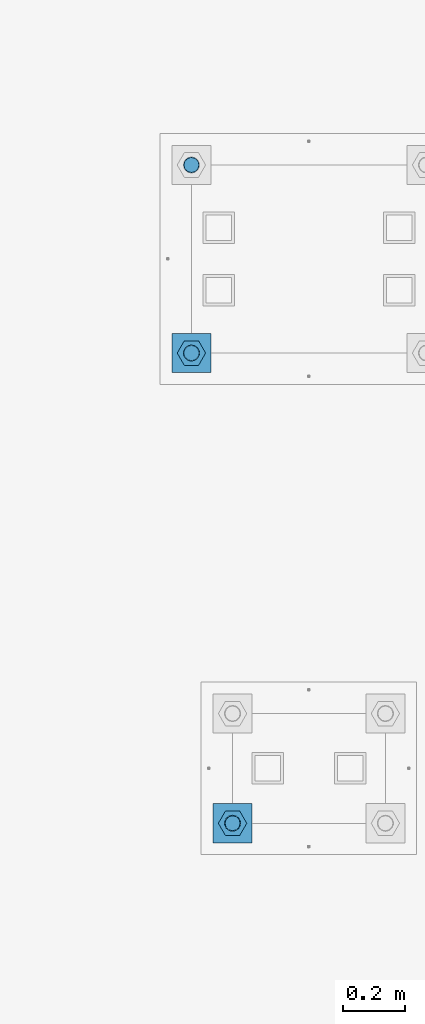
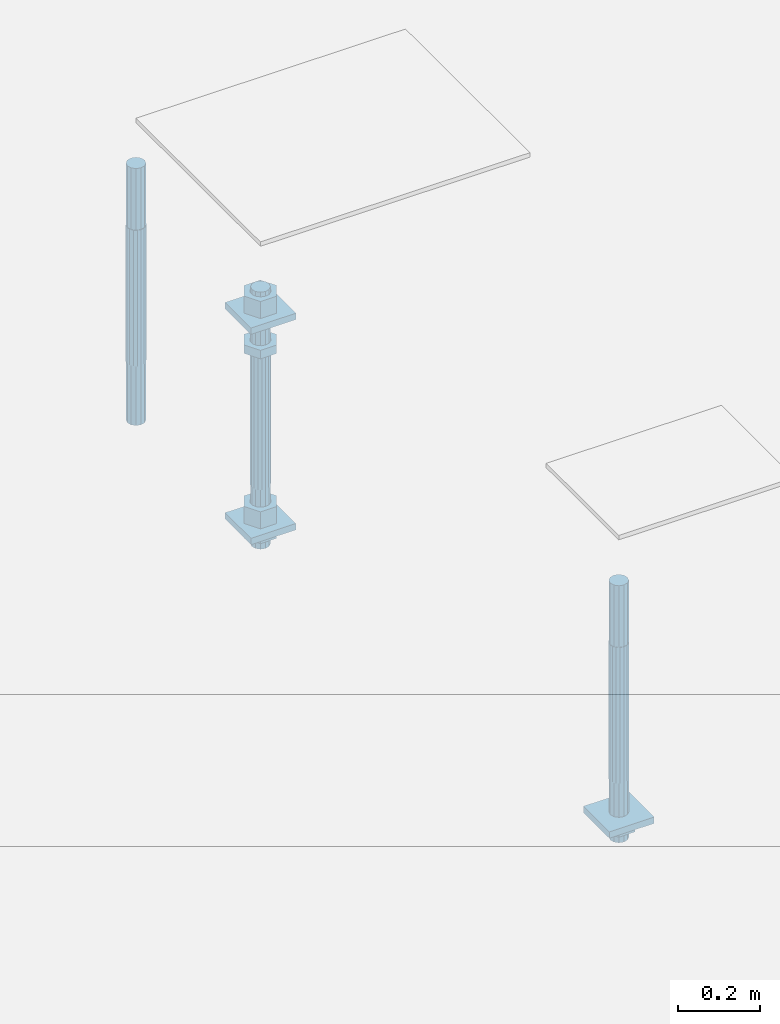
# One storey, part 2558 of 3843: 11 beams, 2 elements without a shape of their own.
"""IFC2X3 building model written with IfcOpenShell, lengths in millimetres."""

import ifcopenshell
import ifcopenshell.guid

model = None  # the IFC model being written
_history = None  # IfcOwnerHistory: only IFC2X3 demands one
_inside = {}  # id of a spatial element -> (the spatial element, [elements in it])
_under = {}  # id of a project, library or spatial element -> (it, [spatial elements below it])
_declared = {}  # id of a project -> (the project, [libraries it declares])
_typed = {}  # id of a type object -> (the type object, [elements of that type])
_made_of = {}  # id of a material, layer set ... -> (it, [elements and type objects made of it])


def new_model(schema):
    """Start an empty IFC model of exactly this schema.

    Asked for "IFC4X3", IfcOpenShell would pick the latest addendum, in which some entities
    have other attributes; the version numbers below select the first issue.
    IFC2X3 requires an IfcOwnerHistory on every rooted entity: one is made here for all.
    """
    global model, _history
    if schema == "IFC4X3":
        model = ifcopenshell.file(schema_version=(4, 3, 0, 0))
    else:
        model = ifcopenshell.file(schema=schema)
    _inside.clear()
    _under.clear()
    _declared.clear()
    _typed.clear()
    _made_of.clear()
    _history = None
    if model.schema == "IFC2X3":
        org = make("IfcOrganization", Name="unknown")
        user = make(
            "IfcPersonAndOrganization",
            ThePerson=make("IfcPerson", FamilyName="unknown"),
            TheOrganization=org,
        )
        app = make(
            "IfcApplication",
            ApplicationDeveloper=org,
            Version="unknown",
            ApplicationFullName="unknown",
            ApplicationIdentifier="unknown",
        )
        _history = make(
            "IfcOwnerHistory",
            OwningUser=user,
            OwningApplication=app,
            ChangeAction="ADDED",
            CreationDate=0,
        )
    return model


def make(cls, **values):
    """One entity of the class cls with the attributes given. An attribute that is None is left unset."""
    return model.create_entity(
        cls, **{name: value for name, value in values.items() if value is not None}
    )


def rooted(cls, **values):
    """An entity with a GlobalId (a new one), such as an element, a storey or a relation."""
    return make(cls, GlobalId=ifcopenshell.guid.new(), OwnerHistory=_history, **values)


def si_unit(unit_type, name, prefix=None):
    """IfcSIUnit, for example si_unit("LENGTHUNIT", "METRE", prefix="MILLI")."""
    return make("IfcSIUnit", UnitType=unit_type, Prefix=prefix, Name=name)


def assignment(units):
    """IfcUnitAssignment: the units of a project."""
    return None if units is None else make("IfcUnitAssignment", Units=units)


def point(xyz):
    """IfcCartesianPoint."""
    return None if xyz is None else make("IfcCartesianPoint", Coordinates=xyz)


def direction(xyz):
    """IfcDirection."""
    return None if xyz is None else make("IfcDirection", DirectionRatios=xyz)


def frame(location, z_axis=None, x_axis=None):
    """IfcAxis2Placement3D, a coordinate frame: its origin and axes. An axis left out is left unset."""
    return make(
        "IfcAxis2Placement3D",
        Location=point(location),
        Axis=direction(z_axis),
        RefDirection=direction(x_axis),
    )


def origin_with_axes():
    """The frame at (0, 0, 0) with the z axis (0, 0, 1) and the x axis (1, 0, 0) written out."""
    return frame((0.0, 0.0, 0.0), z_axis=(0.0, 0.0, 1.0), x_axis=(1.0, 0.0, 0.0))


def place(relative_to, where):
    """IfcLocalPlacement: puts the frame where relative to a parent placement (None: the world)."""
    return make(
        "IfcLocalPlacement", PlacementRelTo=relative_to, RelativePlacement=where
    )


def context(
    kind, dimensions, precision=None, world=None, true_north=None, identifier=None
):
    """IfcGeometricRepresentationContext, for example the 3D "Model" context."""
    return make(
        "IfcGeometricRepresentationContext",
        ContextIdentifier=identifier,
        ContextType=kind,
        CoordinateSpaceDimension=dimensions,
        Precision=precision,
        WorldCoordinateSystem=world,
        TrueNorth=true_north,
    )


def subcontext(parent, identifier, kind, view, scale=None):
    """IfcGeometricRepresentationSubContext, for example "Body" below "Model"."""
    return make(
        "IfcGeometricRepresentationSubContext",
        ContextIdentifier=identifier,
        ContextType=kind,
        ParentContext=parent,
        TargetScale=scale,
        TargetView=view,
    )


def project(units=None, contexts=None):
    """IfcProject with its units and contexts."""
    return rooted(
        "IfcProject",
        Name="project",
        RepresentationContexts=contexts,
        UnitsInContext=assignment(units),
    )


def spatial(cls, under=None, at=None, **own):
    """A site, building, storey or space (cls), placed at a placement, below another one or the project."""
    s = rooted(cls, ObjectPlacement=at, **own)
    if under is not None:
        _under.setdefault(under.id(), (under, []))[1].append(s)
    return s


def faces_of(points, faces, orient=None, outer=None):
    """IfcFace entities. A face is a list of loops; a loop is a list of indices into points, from 0.

    orient and outer hold one flag for each loop. By default every Orientation is true, the
    first loop of a face is its IfcFaceOuterBound and the others are IfcFaceBound.
    """
    made = []
    for i, loops in enumerate(faces):
        bounds = []
        for j, loop in enumerate(loops):
            is_outer = j == 0 if outer is None else outer[i][j]
            bounds.append(
                make(
                    "IfcFaceOuterBound" if is_outer else "IfcFaceBound",
                    Bound=make("IfcPolyLoop", Polygon=[points[k] for k in loop]),
                    Orientation=True if orient is None else orient[i][j],
                )
            )
        made.append(make("IfcFace", Bounds=bounds))
    return made


def faceted_brep(points, faces, orient=None, outer=None, voids=None):
    """IfcFacetedBrep: a solid bounded by flat faces; with voids (closed shells), ...WithVoids."""
    shared = [point(p) for p in points]
    hull = make("IfcClosedShell", CfsFaces=faces_of(shared, faces, orient, outer))
    if voids is None:
        return make("IfcFacetedBrep", Outer=hull)
    return make(
        "IfcFacetedBrepWithVoids",
        Outer=hull,
        Voids=[
            make(cls, CfsFaces=faces_of(shared, fs, o, b)) for cls, fs, o, b in voids
        ],
    )


def shape(context_of_items, identifier, shape_type, items):
    """IfcShapeRepresentation: the items that make up one representation, for example the "Body"."""
    return make(
        "IfcShapeRepresentation",
        ContextOfItems=context_of_items,
        RepresentationIdentifier=identifier,
        RepresentationType=shape_type,
        Items=items,
    )


def material(Name=None, Category=None):
    """IfcMaterial."""
    return make("IfcMaterial", Name=Name, Category=Category)


def made_of(thing, what):
    """Note that an element or type object is made of a material, layer set ...; save() writes the relation."""
    if what is not None:
        _made_of.setdefault(what.id(), (what, []))[1].append(thing)
    return thing


def type_object(cls, material=None, **own):
    """A type object (cls), such as IfcWallType, which elements share."""
    return made_of(rooted(cls, **own), material)


def element(
    cls,
    number,
    at=None,
    inside=None,
    cuts=None,
    type_object=None,
    material=None,
    context=None,
    identifier="Body",
    shape_type=None,
    held_by="IfcProductDefinitionShape",
    body=None,
    shapes=None,
    **own,
):
    """One element of the class cls, such as IfcWall. Its Tag is "e" and its number.

    at: its placement. inside: the storey or other place that contains it. cuts: it is an
    opening in that element (IfcRelVoidsElement). A single representation is given by context,
    identifier, shape_type and body (its items); several are given by shapes. held_by: the class
    of the entity that holds the representations. save() writes the other relations.
    """
    e = rooted(cls, Tag="e%d" % number, ObjectPlacement=at, **own)
    if body is not None:
        shapes = [shape(context, identifier, shape_type, body)]
    if shapes is not None:
        e.Representation = make(held_by, Representations=shapes)
    if inside is not None:
        _inside.setdefault(inside.id(), (inside, []))[1].append(e)
    if cuts is not None:
        rooted(
            "IfcRelVoidsElement", RelatingBuildingElement=cuts, RelatedOpeningElement=e
        )
    if type_object is not None:
        _typed.setdefault(type_object.id(), (type_object, []))[1].append(e)
    return made_of(e, material)


def aggregate(whole, parts):
    """IfcRelAggregates: a whole, such as a stair, and the parts it consists of."""
    return rooted("IfcRelAggregates", RelatingObject=whole, RelatedObjects=parts)


def save(model, path):
    """Write the relations noted so far, then the file.

    IfcRelAggregates (storeys below a building ...), IfcRelContainedInSpatialStructure (elements
    in a storey), IfcRelDefinesByType, IfcRelAssociatesMaterial and IfcRelDeclares: one each for
    every whole, place, type object, material and project.
    """
    for whole, parts in _under.values():
        aggregate(whole, parts)
    for where, things in _inside.values():
        rooted(
            "IfcRelContainedInSpatialStructure",
            RelatedElements=things,
            RelatingStructure=where,
        )
    for kind, things in _typed.values():
        rooted("IfcRelDefinesByType", RelatedObjects=things, RelatingType=kind)
    for what, things in _made_of.values():
        rooted("IfcRelAssociatesMaterial", RelatedObjects=things, RelatingMaterial=what)
    for by, libraries in _declared.values():
        rooted("IfcRelDeclares", RelatingContext=by, RelatedDefinitions=libraries)
    model.write(path)


model = new_model("IFC2X3")

# Units and contexts
model_context = context("Model", 3, precision=1e-05, world=origin_with_axes())
body_context = subcontext(model_context, "Body", "Model", "MODEL_VIEW")
ifc_project = project(units=[si_unit("LENGTHUNIT", "METRE", prefix="MILLI"), si_unit("AREAUNIT", "SQUARE_METRE"), si_unit("VOLUMEUNIT", "CUBIC_METRE"), si_unit("MASSUNIT", "GRAM", prefix="KILO"), si_unit("TIMEUNIT", "SECOND"), si_unit("PLANEANGLEUNIT", "RADIAN"), si_unit("SOLIDANGLEUNIT", "STERADIAN"), si_unit("THERMODYNAMICTEMPERATUREUNIT", "DEGREE_CELSIUS"), si_unit("LUMINOUSINTENSITYUNIT", "LUMEN")], contexts=[model_context])

# Site, building, storey
site_placement = place(None, origin_with_axes())
site = spatial("IfcSite", under=ifc_project, at=site_placement, CompositionType="ELEMENT")
building_placement = place(site_placement, origin_with_axes())
building = spatial("IfcBuilding", under=site, at=building_placement, Name="Undefined", CompositionType="ELEMENT")
storey_placement = place(building_placement, origin_with_axes())
storey = spatial("IfcBuildingStorey", under=building, at=storey_placement, Name="Undefined", CompositionType="ELEMENT", Elevation=0.0)

# Assembly, beam
assembly_1_placement = place(storey_placement, origin_with_axes())
assembly_1 = element("IfcElementAssembly", 1, at=assembly_1_placement, inside=storey, Name="TEMPLATE", AssemblyPlace="NOTDEFINED", PredefinedType="RIGID_FRAME")
ifc_material_1 = material(Name="STEEL/A572-50")
beam_type_1 = type_object("IfcBeamType", PredefinedType="NOTDEFINED")
beam_1_placement = place(assembly_1_placement, frame((104908.35, -114.300001525879, 29244.925), z_axis=(-1.0, 0.0, 0.0), x_axis=(0.0, -1.0, 0.0)))
beam_1 = element("IfcBeam", 2, at=beam_1_placement, type_object=beam_type_1, material=ifc_material_1, Name="WASHER_PLATE", context=body_context, shape_type="Brep", body=[
    faceted_brep([(0.0, 9.52500000000146, -63.5), (0.0, 9.52500000000146, 63.5), (127.0, 9.52500000000146, 63.5), (127.0, 9.52500000000146, -63.5), (0.0, -9.52500000000146, 63.5), (127.0, -9.52500000000146, 63.5), (0.0, -9.52500000000146, -63.5), (127.0, -9.52500000000146, -63.5)], [[[0, 1, 2, 3]], [[1, 4, 5, 2]], [[4, 6, 7, 5]], [[6, 0, 3, 7]], [[5, 7, 3, 2]], [[6, 4, 1, 0]]]),
])

# Assembly, beams
assembly_2_placement = place(storey_placement, origin_with_axes())
assembly_2 = element("IfcElementAssembly", 3, at=assembly_2_placement, inside=storey, Name="TEMPLATE", AssemblyPlace="NOTDEFINED", PredefinedType="RIGID_FRAME")
beam_2_placement = place(assembly_2_placement, frame((104775.0, 1282.70000152587, 29873.575), z_axis=(1.0, 0.0, 0.0), x_axis=(0.0, 1.0, 0.0)))
beam_2 = element("IfcBeam", 4, at=beam_2_placement, type_object=beam_type_1, material=ifc_material_1, Name="WASHER_PLATE", context=body_context, shape_type="Brep", body=[
    faceted_brep([(0.0, 9.52500000000146, -63.5), (0.0, 9.52500000000146, 63.5), (127.0, 9.52500000000146, 63.5), (127.0, 9.52500000000146, -63.5), (0.0, -9.52500000000146, 63.5), (127.0, -9.52500000000146, 63.5), (0.0, -9.52500000000146, -63.5), (127.0, -9.52500000000146, -63.5)], [[[0, 1, 2, 3]], [[1, 4, 5, 2]], [[4, 6, 7, 5]], [[6, 0, 3, 7]], [[5, 7, 3, 2]], [[6, 4, 1, 0]]]),
])
beam_3_placement = place(assembly_2_placement, frame((104775.0, 1282.70000152587, 29244.925), z_axis=(1.0, 0.0, 0.0), x_axis=(0.0, 1.0, 0.0)))
beam_3 = element("IfcBeam", 5, at=beam_3_placement, type_object=beam_type_1, material=ifc_material_1, Name="WASHER_PLATE", context=body_context, shape_type="Brep", body=[
    faceted_brep([(0.0, 9.52500000000146, -63.5), (0.0, 9.52500000000146, 63.5), (127.0, 9.52500000000146, 63.5), (127.0, 9.52500000000146, -63.5), (0.0, -9.52500000000146, 63.5), (127.0, -9.52500000000146, 63.5), (0.0, -9.52500000000146, -63.5), (127.0, -9.52500000000146, -63.5)], [[[0, 1, 2, 3]], [[1, 4, 5, 2]], [[4, 6, 7, 5]], [[6, 0, 3, 7]], [[5, 7, 3, 2]], [[6, 4, 1, 0]]]),
])

# Beam
ifc_material_2 = material(Name="STEEL/A36")
beam_type_2 = type_object("IfcBeamType", Name="2_HALF_NUT", PredefinedType="NOTDEFINED")
beam_4_placement = place(assembly_1_placement, frame((104908.35, -177.800001525879, 29235.4), z_axis=(0.0, -1.0, 0.0), x_axis=(0.0, 0.0, -1.0)))
beam_4 = element("IfcBeam", 6, at=beam_4_placement, type_object=beam_type_2, material=ifc_material_2, Name="NUT", ObjectType="2_HALF_NUT", context=body_context, shape_type="Brep", body=[
    faceted_brep([(0.0, -46.0369987487793, 0.0), (0.0, -23.0184993743896, -39.869213104248), (25.4000000000015, -23.0184993743896, -39.869213104248), (25.4000000000015, -46.0369987487793, 0.0), (0.0, 23.0184993743896, -39.869213104248), (25.4000000000015, 23.0184993743896, -39.869213104248), (0.0, 46.0369987487793, 0.0), (25.4000000000015, 46.0369987487793, 0.0), (0.0, 23.0184993743896, 39.869213104248), (25.4000000000015, 23.0184993743896, 39.869213104248), (0.0, -23.0184993743896, 39.869213104248), (25.4000000000015, -23.0184993743896, 39.869213104248), (0.0, 0.0, 26.1940002441406), (0.0, 11.3650617044477, 23.5999013092805), (25.4000000000015, 11.3650617044477, 23.5999013092805), (25.4000000000015, 0.0, 26.1940002441406), (0.0, 20.4791109456419, 16.3316083006721), (25.4000000000015, 20.4791109456419, 16.3316083006721), (0.0, 25.5370200498292, 5.82867859874386), (25.4000000000015, 25.5370200498292, 5.82867859874386), (0.0, 25.5370200498292, -5.82867859874386), (25.4000000000015, 25.5370200498292, -5.82867859874386), (0.0, 20.4791109456419, -16.3316083006721), (25.4000000000015, 20.4791109456419, -16.3316083006721), (0.0, 11.3650617044477, -23.5999013092805), (25.4000000000015, 11.3650617044477, -23.5999013092805), (0.0, 0.0, -26.1940002441406), (25.4000000000015, 0.0, -26.1940002441406), (0.0, -11.3650617044477, -23.5999013092805), (25.4000000000015, -11.3650617044477, -23.5999013092805), (0.0, -20.4791109456419, -16.3316083006721), (25.4000000000015, -20.4791109456419, -16.3316083006721), (0.0, -25.5370200498292, -5.82867859874386), (25.4000000000015, -25.5370200498292, -5.82867859874386), (0.0, -25.5370200498292, 5.82867859874386), (25.4000000000015, -25.5370200498292, 5.82867859874386), (0.0, -20.4791109456419, 16.3316083006721), (25.4000000000015, -20.4791109456419, 16.3316083006721), (0.0, -11.3650617044477, 23.5999013092805), (25.4000000000015, -11.3650617044477, 23.5999013092805)], [[[0, 1, 2, 3]], [[1, 4, 5, 2]], [[4, 6, 7, 5]], [[6, 8, 9, 7]], [[8, 10, 11, 9]], [[10, 0, 3, 11]], [[12, 13, 14, 15]], [[13, 16, 17, 14]], [[16, 18, 19, 17]], [[18, 20, 21, 19]], [[20, 22, 23, 21]], [[22, 24, 25, 23]], [[24, 26, 27, 25]], [[26, 28, 29, 27]], [[28, 30, 31, 29]], [[30, 32, 33, 31]], [[32, 34, 35, 33]], [[34, 36, 37, 35]], [[36, 38, 39, 37]], [[38, 12, 15, 39]], [[5, 7, 9, 11, 3, 2], [17, 19, 21, 23, 25, 27, 29, 31, 33, 35, 37, 39, 15, 14]], [[10, 8, 6, 4, 1, 0], [38, 36, 34, 32, 30, 28, 26, 24, 22, 20, 18, 16, 13, 12]]]),
])

beam_5_placement = place(assembly_2_placement, frame((104775.0, 1346.20000152587, 29787.85), z_axis=(0.0, 1.0, 0.0), x_axis=(0.0, 0.0, -1.0)))
beam_5 = element("IfcBeam", 7, at=beam_5_placement, type_object=beam_type_2, material=ifc_material_2, Name="NUT", ObjectType="2_HALF_NUT", context=body_context, shape_type="Brep", body=[
    faceted_brep([(0.0, -46.0369987487793, 0.0), (0.0, -23.0184993743896, -39.869213104248), (25.4000000000015, -23.0184993743896, -39.869213104248), (25.4000000000015, -46.0369987487793, 0.0), (0.0, 23.0184993743896, -39.869213104248), (25.4000000000015, 23.0184993743896, -39.869213104248), (0.0, 46.0369987487793, 0.0), (25.4000000000015, 46.0369987487793, 0.0), (0.0, 23.0184993743896, 39.869213104248), (25.4000000000015, 23.0184993743896, 39.869213104248), (0.0, -23.0184993743896, 39.869213104248), (25.4000000000015, -23.0184993743896, 39.869213104248), (0.0, 0.0, 26.1940002441406), (0.0, 11.3650617044477, 23.5999013092805), (25.4000000000015, 11.3650617044477, 23.5999013092805), (25.4000000000015, 0.0, 26.1940002441406), (0.0, 20.4791109456419, 16.3316083006721), (25.4000000000015, 20.4791109456419, 16.3316083006721), (0.0, 25.5370200498292, 5.82867859874386), (25.4000000000015, 25.5370200498292, 5.82867859874386), (0.0, 25.5370200498292, -5.82867859874386), (25.4000000000015, 25.5370200498292, -5.82867859874386), (0.0, 20.4791109456419, -16.3316083006721), (25.4000000000015, 20.4791109456419, -16.3316083006721), (0.0, 11.3650617044477, -23.5999013092805), (25.4000000000015, 11.3650617044477, -23.5999013092805), (0.0, 0.0, -26.1940002441406), (25.4000000000015, 0.0, -26.1940002441406), (0.0, -11.3650617044477, -23.5999013092805), (25.4000000000015, -11.3650617044477, -23.5999013092805), (0.0, -20.4791109456419, -16.3316083006721), (25.4000000000015, -20.4791109456419, -16.3316083006721), (0.0, -25.5370200498292, -5.82867859874386), (25.4000000000015, -25.5370200498292, -5.82867859874386), (0.0, -25.5370200498292, 5.82867859874386), (25.4000000000015, -25.5370200498292, 5.82867859874386), (0.0, -20.4791109456419, 16.3316083006721), (25.4000000000015, -20.4791109456419, 16.3316083006721), (0.0, -11.3650617044477, 23.5999013092805), (25.4000000000015, -11.3650617044477, 23.5999013092805)], [[[0, 1, 2, 3]], [[1, 4, 5, 2]], [[4, 6, 7, 5]], [[6, 8, 9, 7]], [[8, 10, 11, 9]], [[10, 0, 3, 11]], [[12, 13, 14, 15]], [[13, 16, 17, 14]], [[16, 18, 19, 17]], [[18, 20, 21, 19]], [[20, 22, 23, 21]], [[22, 24, 25, 23]], [[24, 26, 27, 25]], [[26, 28, 29, 27]], [[28, 30, 31, 29]], [[30, 32, 33, 31]], [[32, 34, 35, 33]], [[34, 36, 37, 35]], [[36, 38, 39, 37]], [[38, 12, 15, 39]], [[5, 7, 9, 11, 3, 2], [17, 19, 21, 23, 25, 27, 29, 31, 33, 35, 37, 39, 15, 14]], [[10, 8, 6, 4, 1, 0], [38, 36, 34, 32, 30, 28, 26, 24, 22, 20, 18, 16, 13, 12]]]),
])

beam_6_placement = place(assembly_2_placement, frame((104775.0, 1346.20000152587, 29235.4), z_axis=(0.0, 1.0, 0.0), x_axis=(0.0, 0.0, -1.0)))
beam_6 = element("IfcBeam", 8, at=beam_6_placement, type_object=beam_type_2, material=ifc_material_2, Name="NUT", ObjectType="2_HALF_NUT", context=body_context, shape_type="Brep", body=[
    faceted_brep([(0.0, -46.0369987487793, 0.0), (0.0, -23.0184993743896, -39.869213104248), (25.4000000000015, -23.0184993743896, -39.869213104248), (25.4000000000015, -46.0369987487793, 0.0), (0.0, 23.0184993743896, -39.869213104248), (25.4000000000015, 23.0184993743896, -39.869213104248), (0.0, 46.0369987487793, 0.0), (25.4000000000015, 46.0369987487793, 0.0), (0.0, 23.0184993743896, 39.869213104248), (25.4000000000015, 23.0184993743896, 39.869213104248), (0.0, -23.0184993743896, 39.869213104248), (25.4000000000015, -23.0184993743896, 39.869213104248), (0.0, 0.0, 26.1940002441406), (0.0, 11.3650617044477, 23.5999013092805), (25.4000000000015, 11.3650617044477, 23.5999013092805), (25.4000000000015, 0.0, 26.1940002441406), (0.0, 20.4791109456419, 16.3316083006721), (25.4000000000015, 20.4791109456419, 16.3316083006721), (0.0, 25.5370200498292, 5.82867859874386), (25.4000000000015, 25.5370200498292, 5.82867859874386), (0.0, 25.5370200498292, -5.82867859874386), (25.4000000000015, 25.5370200498292, -5.82867859874386), (0.0, 20.4791109456419, -16.3316083006721), (25.4000000000015, 20.4791109456419, -16.3316083006721), (0.0, 11.3650617044477, -23.5999013092805), (25.4000000000015, 11.3650617044477, -23.5999013092805), (0.0, 0.0, -26.1940002441406), (25.4000000000015, 0.0, -26.1940002441406), (0.0, -11.3650617044477, -23.5999013092805), (25.4000000000015, -11.3650617044477, -23.5999013092805), (0.0, -20.4791109456419, -16.3316083006721), (25.4000000000015, -20.4791109456419, -16.3316083006721), (0.0, -25.5370200498292, -5.82867859874386), (25.4000000000015, -25.5370200498292, -5.82867859874386), (0.0, -25.5370200498292, 5.82867859874386), (25.4000000000015, -25.5370200498292, 5.82867859874386), (0.0, -20.4791109456419, 16.3316083006721), (25.4000000000015, -20.4791109456419, 16.3316083006721), (0.0, -11.3650617044477, 23.5999013092805), (25.4000000000015, -11.3650617044477, 23.5999013092805)], [[[0, 1, 2, 3]], [[1, 4, 5, 2]], [[4, 6, 7, 5]], [[6, 8, 9, 7]], [[8, 10, 11, 9]], [[10, 0, 3, 11]], [[12, 13, 14, 15]], [[13, 16, 17, 14]], [[16, 18, 19, 17]], [[18, 20, 21, 19]], [[20, 22, 23, 21]], [[22, 24, 25, 23]], [[24, 26, 27, 25]], [[26, 28, 29, 27]], [[28, 30, 31, 29]], [[30, 32, 33, 31]], [[32, 34, 35, 33]], [[34, 36, 37, 35]], [[36, 38, 39, 37]], [[38, 12, 15, 39]], [[5, 7, 9, 11, 3, 2], [17, 19, 21, 23, 25, 27, 29, 31, 33, 35, 37, 39, 15, 14]], [[10, 8, 6, 4, 1, 0], [38, 36, 34, 32, 30, 28, 26, 24, 22, 20, 18, 16, 13, 12]]]),
])

beam_type_3 = type_object("IfcBeamType", Name="2_HEAVY_HEX_NUT", PredefinedType="NOTDEFINED")
beam_7_placement = place(assembly_2_placement, frame((104775.0, 1346.20000152587, 29933.9), z_axis=(0.0, 1.0, 0.0), x_axis=(0.0, 0.0, -1.0)))
beam_7 = element("IfcBeam", 9, at=beam_7_placement, type_object=beam_type_3, material=ifc_material_2, Name="NUT", ObjectType="2_HEAVY_HEX_NUT", context=body_context, shape_type="Brep", body=[
    faceted_brep([(0.0, -46.0369987487793, 0.0), (0.0, -23.0184993743896, -39.869213104248), (50.7999999999993, -23.0184993743896, -39.869213104248), (50.7999999999993, -46.0369987487793, 0.0), (0.0, 23.0184993743896, -39.869213104248), (50.7999999999993, 23.0184993743896, -39.869213104248), (0.0, 46.0369987487793, 0.0), (50.7999999999993, 46.0369987487793, 0.0), (0.0, 23.0184993743896, 39.869213104248), (50.7999999999993, 23.0184993743896, 39.869213104248), (0.0, -23.0184993743896, 39.869213104248), (50.7999999999993, -23.0184993743896, 39.869213104248), (0.0, 0.0, 26.1940002441406), (0.0, 11.3650617044477, 23.5999013092805), (50.7999999999993, 11.3650617044477, 23.5999013092805), (50.7999999999993, 0.0, 26.1940002441406), (0.0, 20.4791109456419, 16.3316083006721), (50.7999999999993, 20.4791109456419, 16.3316083006721), (0.0, 25.5370200498292, 5.82867859874386), (50.7999999999993, 25.5370200498292, 5.82867859874386), (0.0, 25.5370200498292, -5.82867859874386), (50.7999999999993, 25.5370200498292, -5.82867859874386), (0.0, 20.4791109456419, -16.3316083006721), (50.7999999999993, 20.4791109456419, -16.3316083006721), (0.0, 11.3650617044477, -23.5999013092805), (50.7999999999993, 11.3650617044477, -23.5999013092805), (0.0, 0.0, -26.1940002441406), (50.7999999999993, 0.0, -26.1940002441406), (0.0, -11.3650617044477, -23.5999013092805), (50.7999999999993, -11.3650617044477, -23.5999013092805), (0.0, -20.4791109456419, -16.3316083006721), (50.7999999999993, -20.4791109456419, -16.3316083006721), (0.0, -25.5370200498292, -5.82867859874386), (50.7999999999993, -25.5370200498292, -5.82867859874386), (0.0, -25.5370200498292, 5.82867859874386), (50.7999999999993, -25.5370200498292, 5.82867859874386), (0.0, -20.4791109456419, 16.3316083006721), (50.7999999999993, -20.4791109456419, 16.3316083006721), (0.0, -11.3650617044477, 23.5999013092805), (50.7999999999993, -11.3650617044477, 23.5999013092805)], [[[0, 1, 2, 3]], [[1, 4, 5, 2]], [[4, 6, 7, 5]], [[6, 8, 9, 7]], [[8, 10, 11, 9]], [[10, 0, 3, 11]], [[12, 13, 14, 15]], [[13, 16, 17, 14]], [[16, 18, 19, 17]], [[18, 20, 21, 19]], [[20, 22, 23, 21]], [[22, 24, 25, 23]], [[24, 26, 27, 25]], [[26, 28, 29, 27]], [[28, 30, 31, 29]], [[30, 32, 33, 31]], [[32, 34, 35, 33]], [[34, 36, 37, 35]], [[36, 38, 39, 37]], [[38, 12, 15, 39]], [[5, 7, 9, 11, 3, 2], [17, 19, 21, 23, 25, 27, 29, 31, 33, 35, 37, 39, 15, 14]], [[10, 8, 6, 4, 1, 0], [38, 36, 34, 32, 30, 28, 26, 24, 22, 20, 18, 16, 13, 12]]]),
])

beam_8_placement = place(assembly_2_placement, frame((104775.0, 1346.20000152587, 29305.25), z_axis=(0.0, 1.0, 0.0), x_axis=(0.0, 0.0, -1.0)))
beam_8 = element("IfcBeam", 10, at=beam_8_placement, type_object=beam_type_3, material=ifc_material_2, Name="NUT", ObjectType="2_HEAVY_HEX_NUT", context=body_context, shape_type="Brep", body=[
    faceted_brep([(0.0, -46.0369987487793, 0.0), (0.0, -23.0184993743896, -39.869213104248), (50.7999999999993, -23.0184993743896, -39.869213104248), (50.7999999999993, -46.0369987487793, 0.0), (0.0, 23.0184993743896, -39.869213104248), (50.7999999999993, 23.0184993743896, -39.869213104248), (0.0, 46.0369987487793, 0.0), (50.7999999999993, 46.0369987487793, 0.0), (0.0, 23.0184993743896, 39.869213104248), (50.7999999999993, 23.0184993743896, 39.869213104248), (0.0, -23.0184993743896, 39.869213104248), (50.7999999999993, -23.0184993743896, 39.869213104248), (0.0, 0.0, 26.1940002441406), (0.0, 11.3650617044477, 23.5999013092805), (50.7999999999993, 11.3650617044477, 23.5999013092805), (50.7999999999993, 0.0, 26.1940002441406), (0.0, 20.4791109456419, 16.3316083006721), (50.7999999999993, 20.4791109456419, 16.3316083006721), (0.0, 25.5370200498292, 5.82867859874386), (50.7999999999993, 25.5370200498292, 5.82867859874386), (0.0, 25.5370200498292, -5.82867859874386), (50.7999999999993, 25.5370200498292, -5.82867859874386), (0.0, 20.4791109456419, -16.3316083006721), (50.7999999999993, 20.4791109456419, -16.3316083006721), (0.0, 11.3650617044477, -23.5999013092805), (50.7999999999993, 11.3650617044477, -23.5999013092805), (0.0, 0.0, -26.1940002441406), (50.7999999999993, 0.0, -26.1940002441406), (0.0, -11.3650617044477, -23.5999013092805), (50.7999999999993, -11.3650617044477, -23.5999013092805), (0.0, -20.4791109456419, -16.3316083006721), (50.7999999999993, -20.4791109456419, -16.3316083006721), (0.0, -25.5370200498292, -5.82867859874386), (50.7999999999993, -25.5370200498292, -5.82867859874386), (0.0, -25.5370200498292, 5.82867859874386), (50.7999999999993, -25.5370200498292, 5.82867859874386), (0.0, -20.4791109456419, 16.3316083006721), (50.7999999999993, -20.4791109456419, 16.3316083006721), (0.0, -11.3650617044477, 23.5999013092805), (50.7999999999993, -11.3650617044477, 23.5999013092805)], [[[0, 1, 2, 3]], [[1, 4, 5, 2]], [[4, 6, 7, 5]], [[6, 8, 9, 7]], [[8, 10, 11, 9]], [[10, 0, 3, 11]], [[12, 13, 14, 15]], [[13, 16, 17, 14]], [[16, 18, 19, 17]], [[18, 20, 21, 19]], [[20, 22, 23, 21]], [[22, 24, 25, 23]], [[24, 26, 27, 25]], [[26, 28, 29, 27]], [[28, 30, 31, 29]], [[30, 32, 33, 31]], [[32, 34, 35, 33]], [[34, 36, 37, 35]], [[36, 38, 39, 37]], [[38, 12, 15, 39]], [[5, 7, 9, 11, 3, 2], [17, 19, 21, 23, 25, 27, 29, 31, 33, 35, 37, 39, 15, 14]], [[10, 8, 6, 4, 1, 0], [38, 36, 34, 32, 30, 28, 26, 24, 22, 20, 18, 16, 13, 12]]]),
])

ifc_material_3 = material()
beam_type_4 = type_object("IfcBeamType", PredefinedType="NOTDEFINED")
beam_9_placement = place(assembly_1_placement, frame((104908.35, -177.800001525879, 29762.45), z_axis=(0.0, -1.0, 0.0), x_axis=(0.0, 0.0, -1.0)))
beam_9 = element("IfcBeam", 11, at=beam_9_placement, type_object=beam_type_4, material=ifc_material_3, Name="ANCHOR_ROD", context=body_context, shape_type="Brep", body=[
    faceted_brep([(-184.150000000001, -21.217622392709, 12.25), (-184.150000000001, -12.2499999999854, 21.2176223927163), (-184.150000000001, 1.45519152283669e-11, 24.5), (-184.150000000001, 12.2500000000146, 21.2176223927163), (-184.150000000001, 21.2176223927381, 12.25), (-184.150000000001, 24.5000000000146, 0.0), (-184.150000000001, 21.2176223927381, -12.25), (-184.150000000001, 12.2500000000146, -21.2176223927163), (-184.150000000001, 1.45519152283669e-11, -24.5), (-184.150000000001, -12.2499999999854, -21.2176223927163), (-184.150000000001, -21.217622392709, -12.25), (-184.150000000001, -24.4999999999854, 0.0), (0.0, 24.5000000000146, 0.0), (0.0, 21.2176223927381, -12.25), (0.0, 12.2500000000146, -21.2176223927163), (0.0, 1.45519152283669e-11, -24.5), (0.0, -12.2499999999854, -21.2176223927163), (0.0, -21.217622392709, -12.25), (0.0, -24.4999999999854, 0.0), (0.0, -21.217622392709, 12.25), (0.0, -12.2499999999854, 21.2176223927163), (0.0, 1.45519152283669e-11, 24.5), (0.0, 12.2500000000146, 21.2176223927163), (0.0, 21.2176223927381, 12.25), (0.0, -23.4665401257807, 9.72015918207035), (0.0, -17.9605122421344, 17.9605122421417), (0.0, -9.72015918207762, 23.466540125788), (0.0, 0.0, 25.4000000000015), (0.0, 9.72015918207762, 23.466540125788), (0.0, 17.9605122421344, 17.9605122421417), (0.0, 23.4665401257807, 9.72015918207035), (0.0, 25.3999996185303, 0.0), (0.0, 23.4665401257807, -9.72015918207035), (0.0, 17.9605122421344, -17.9605122421417), (0.0, 9.72015918207762, -23.466540125788), (0.0, 0.0, -25.4000000000015), (0.0, -9.72015918207762, -23.466540125788), (0.0, -17.9605122421344, -17.9605122421417), (0.0, -23.4665401257807, -9.72015918207035), (0.0, -25.3999996185303, 0.0), (406.399999999998, -25.3999999999942, 0.0), (406.399999999998, -23.4665401257807, 9.72015918207035), (406.399999999998, -17.9605122421344, 17.9605122421417), (406.399999999998, -9.72015918207762, 23.466540125788), (406.399999999998, 0.0, 25.4000000000015), (406.399999999998, 9.72015918207762, 23.466540125788), (406.399999999998, 17.9605122421344, 17.9605122421417), (406.399999999998, 23.4665401257807, 9.72015918207035), (406.399999999998, 25.3999999999942, 0.0), (406.399999999998, 23.4665401257807, -9.72015918207035), (406.399999999998, 17.9605122421344, -17.9605122421417), (406.399999999998, 9.72015918207762, -23.466540125788), (406.399999999998, 0.0, -25.4000000000015), (406.399999999998, -9.72015918207762, -23.466540125788), (406.399999999998, -17.9605122421344, -17.9605122421417), (406.399999999998, -23.4665401257807, -9.72015918207035), (406.399999999998, -12.2499999999854, 21.2176223927163), (406.399999999998, 1.45519152283669e-11, 24.5), (406.399999999998, 12.2500000000146, 21.2176223927163), (406.399999999998, 21.2176223927381, 12.25), (406.399999999998, 24.5000000000146, 0.0), (406.399999999998, 21.2176223927381, -12.25), (406.399999999998, 12.2500000000146, -21.2176223927163), (406.399999999998, 1.45519152283669e-11, -24.5), (406.399999999998, -12.2499999999854, -21.2176223927163), (406.399999999998, -21.217622392709, -12.25), (406.399999999998, -24.4999999999854, 0.0), (406.399999999998, -21.217622392709, 12.25), (584.200000000001, -12.2499999999854, -21.2176223927163), (584.200000000001, 1.45519152283669e-11, -24.5), (584.200000000001, 12.2500000000146, -21.2176223927163), (584.200000000001, 21.2176223927381, -12.25), (584.200000000001, 24.5000000000146, 0.0), (584.200000000001, 21.2176223927381, 12.25), (584.200000000001, 12.2500000000146, 21.2176223927163), (584.200000000001, 1.45519152283669e-11, 24.5), (584.200000000001, -12.2499999999854, 21.2176223927163), (584.200000000001, -21.217622392709, 12.25), (584.200000000001, -24.4999999999854, 0.0), (584.200000000001, -21.217622392709, -12.25)], [[[0, 1, 2, 3, 4, 5, 6, 7, 8, 9, 10, 11]], [[6, 5, 12, 13]], [[7, 6, 13, 14]], [[8, 7, 14, 15]], [[9, 8, 15, 16]], [[10, 9, 16, 17]], [[11, 10, 17, 18]], [[0, 11, 18, 19]], [[1, 0, 19, 20]], [[2, 1, 20, 21]], [[3, 2, 21, 22]], [[4, 3, 22, 23]], [[5, 4, 23, 12]], [[24, 25, 26, 27, 28, 29, 30, 31, 32, 33, 34, 35, 36, 37, 38, 39], [22, 21, 20, 19, 18, 17, 16, 15, 14, 13, 12, 23]], [[24, 39, 40, 41]], [[25, 24, 41, 42]], [[26, 25, 42, 43]], [[27, 26, 43, 44]], [[28, 27, 44, 45]], [[29, 28, 45, 46]], [[30, 29, 46, 47]], [[31, 30, 47, 48]], [[32, 31, 48, 49]], [[33, 32, 49, 50]], [[34, 33, 50, 51]], [[35, 34, 51, 52]], [[36, 35, 52, 53]], [[37, 36, 53, 54]], [[38, 37, 54, 55]], [[39, 38, 55, 40]], [[54, 53, 52, 51, 50, 49, 48, 47, 46, 45, 44, 43, 42, 41, 40, 55], [56, 57, 58, 59, 60, 61, 62, 63, 64, 65, 66, 67]], [[68, 69, 70, 71, 72, 73, 74, 75, 76, 77, 78, 79]], [[76, 75, 57, 56]], [[77, 76, 56, 67]], [[78, 77, 67, 66]], [[79, 78, 66, 65]], [[68, 79, 65, 64]], [[69, 68, 64, 63]], [[70, 69, 63, 62]], [[71, 70, 62, 61]], [[72, 71, 61, 60]], [[73, 72, 60, 59]], [[74, 73, 59, 58]], [[75, 74, 58, 57]]]),
])

aggregate(assembly_1, [beam_4, beam_1, beam_9])

beam_10_placement = place(assembly_2_placement, frame((104775.000001526, 1955.79999999999, 29762.45), z_axis=(1.0, 0.0, 0.0), x_axis=(0.0, 0.0, -1.0)))
beam_10 = element("IfcBeam", 12, at=beam_10_placement, type_object=beam_type_4, material=ifc_material_3, Name="ANCHOR_ROD", context=body_context, shape_type="Brep", body=[
    faceted_brep([(0.0, -23.4665401257807, -9.72015918207035), (0.0, -17.9605122421344, -17.9605122421417), (406.399999999998, -17.9605122421344, -17.9605122421417), (406.399999999998, -23.4665401257807, -9.72015918207035), (0.0, -9.72015918207762, -23.466540125788), (406.399999999998, -9.72015918207762, -23.466540125788), (0.0, 0.0, -25.4000000000015), (406.399999999998, 0.0, -25.4000000000015), (0.0, 9.72015918207762, -23.466540125788), (406.399999999998, 9.72015918207762, -23.466540125788), (0.0, 17.9605122421344, -17.9605122421417), (406.399999999998, 17.9605122421344, -17.9605122421417), (0.0, 23.4665401257807, -9.72015918207035), (406.399999999998, 23.4665401257807, -9.72015918207035), (0.0, 25.3999996185303, 0.0), (406.399999999998, 25.3999999999942, 0.0), (0.0, 23.4665401257807, 9.72015918207035), (406.399999999998, 23.4665401257807, 9.72015918207035), (0.0, 17.9605122421344, 17.9605122421417), (406.399999999998, 17.9605122421344, 17.9605122421417), (0.0, 9.72015918207762, 23.466540125788), (406.399999999998, 9.72015918207762, 23.466540125788), (0.0, 0.0, 25.4000000000015), (406.399999999998, 0.0, 25.4000000000015), (0.0, -9.72015918207762, 23.466540125788), (406.399999999998, -9.72015918207762, 23.466540125788), (0.0, -17.9605122421344, 17.9605122421417), (406.399999999998, -17.9605122421344, 17.9605122421417), (0.0, -23.4665401257807, 9.72015918207035), (406.399999999998, -23.4665401257807, 9.72015918207035), (0.0, -25.3999996185303, 0.0), (406.399999999998, -25.3999999999942, 0.0), (584.200000000001, -12.2499999999854, -21.2176223927163), (584.200000000001, 1.45519152283669e-11, -24.5), (584.200000000001, 12.2500000000146, -21.2176223927163), (584.200000000001, 21.2176223927381, -12.25), (584.200000000001, 24.5000000000146, 0.0), (584.200000000001, 21.2176223927381, 12.25), (584.200000000001, 12.2500000000146, 21.2176223927163), (584.200000000001, 1.45519152283669e-11, 24.5), (584.200000000001, -12.2499999999854, 21.2176223927163), (584.200000000001, -21.217622392709, 12.25), (584.200000000001, -24.4999999999854, 0.0), (584.200000000001, -21.217622392709, -12.25), (406.399999999998, -24.4999999999854, 0.0), (406.399999999998, -21.217622392709, -12.25), (406.399999999998, -12.2499999999854, -21.2176223927163), (406.399999999998, 1.45519152283669e-11, -24.5), (406.399999999998, 12.2500000000146, -21.2176223927163), (406.399999999998, 21.2176223927381, -12.25), (406.399999999998, 24.5000000000146, 0.0), (406.399999999998, 21.2176223927381, 12.25), (406.399999999998, 12.2500000000146, 21.2176223927163), (406.399999999998, 1.45519152283669e-11, 24.5), (406.399999999998, -12.2499999999854, 21.2176223927163), (406.399999999998, -21.217622392709, 12.25), (0.0, 12.2500000000146, 21.2176223927163), (0.0, 1.45519152283669e-11, 24.5), (0.0, -12.2499999999854, 21.2176223927163), (0.0, -21.217622392709, 12.25), (0.0, -24.4999999999854, 0.0), (0.0, -21.217622392709, -12.25), (0.0, -12.2499999999854, -21.2176223927163), (0.0, 1.45519152283669e-11, -24.5), (0.0, 12.2500000000146, -21.2176223927163), (0.0, 21.2176223927381, -12.25), (0.0, 24.5000000000146, 0.0), (0.0, 21.2176223927381, 12.25), (-184.150000000001, -21.217622392709, 12.25), (-184.150000000001, -12.2499999999854, 21.2176223927163), (-184.150000000001, 1.45519152283669e-11, 24.5), (-184.150000000001, 12.2500000000146, 21.2176223927163), (-184.150000000001, 21.2176223927381, 12.25), (-184.150000000001, 24.5000000000146, 0.0), (-184.150000000001, 21.2176223927381, -12.25), (-184.150000000001, 12.2500000000146, -21.2176223927163), (-184.150000000001, 1.45519152283669e-11, -24.5), (-184.150000000001, -12.2499999999854, -21.2176223927163), (-184.150000000001, -21.217622392709, -12.25), (-184.150000000001, -24.4999999999854, 0.0)], [[[0, 1, 2, 3]], [[1, 4, 5, 2]], [[4, 6, 7, 5]], [[6, 8, 9, 7]], [[8, 10, 11, 9]], [[10, 12, 13, 11]], [[12, 14, 15, 13]], [[14, 16, 17, 15]], [[16, 18, 19, 17]], [[18, 20, 21, 19]], [[20, 22, 23, 21]], [[22, 24, 25, 23]], [[24, 26, 27, 25]], [[26, 28, 29, 27]], [[28, 30, 31, 29]], [[32, 33, 34, 35, 36, 37, 38, 39, 40, 41, 42, 43]], [[43, 42, 44, 45]], [[32, 43, 45, 46]], [[33, 32, 46, 47]], [[34, 33, 47, 48]], [[35, 34, 48, 49]], [[36, 35, 49, 50]], [[37, 36, 50, 51]], [[38, 37, 51, 52]], [[39, 38, 52, 53]], [[40, 39, 53, 54]], [[41, 40, 54, 55]], [[42, 41, 55, 44]], [[2, 5, 7, 9, 11, 13, 15, 17, 19, 21, 23, 25, 27, 29, 31, 3], [54, 53, 52, 51, 50, 49, 48, 47, 46, 45, 44, 55]], [[30, 0, 3, 31]], [[28, 26, 24, 22, 20, 18, 16, 14, 12, 10, 8, 6, 4, 1, 0, 30], [56, 57, 58, 59, 60, 61, 62, 63, 64, 65, 66, 67]], [[68, 69, 70, 71, 72, 73, 74, 75, 76, 77, 78, 79]], [[71, 70, 57, 56]], [[72, 71, 56, 67]], [[73, 72, 67, 66]], [[74, 73, 66, 65]], [[75, 74, 65, 64]], [[76, 75, 64, 63]], [[77, 76, 63, 62]], [[78, 77, 62, 61]], [[79, 78, 61, 60]], [[68, 79, 60, 59]], [[69, 68, 59, 58]], [[70, 69, 58, 57]]]),
])

beam_11_placement = place(assembly_2_placement, frame((104775.000001526, 1346.19999999998, 29762.45), z_axis=(1.0, 0.0, 0.0), x_axis=(0.0, 0.0, -1.0)))
beam_11 = element("IfcBeam", 13, at=beam_11_placement, type_object=beam_type_4, material=ifc_material_3, Name="ANCHOR_ROD", context=body_context, shape_type="Brep", body=[
    faceted_brep([(0.0, -23.4665401257807, -9.72015918207035), (0.0, -17.9605122421344, -17.9605122421417), (406.399999999998, -17.9605122421344, -17.9605122421417), (406.399999999998, -23.4665401257807, -9.72015918207035), (0.0, -9.72015918207762, -23.466540125788), (406.399999999998, -9.72015918207762, -23.466540125788), (0.0, 0.0, -25.4000000000015), (406.399999999998, 0.0, -25.4000000000015), (0.0, 9.72015918207762, -23.466540125788), (406.399999999998, 9.72015918207762, -23.466540125788), (0.0, 17.9605122421344, -17.9605122421417), (406.399999999998, 17.9605122421344, -17.9605122421417), (0.0, 23.4665401257807, -9.72015918207035), (406.399999999998, 23.4665401257807, -9.72015918207035), (0.0, 25.3999996185303, 0.0), (406.399999999998, 25.3999999999942, 0.0), (0.0, 23.4665401257807, 9.72015918207035), (406.399999999998, 23.4665401257807, 9.72015918207035), (0.0, 17.9605122421344, 17.9605122421417), (406.399999999998, 17.9605122421344, 17.9605122421417), (0.0, 9.72015918207762, 23.466540125788), (406.399999999998, 9.72015918207762, 23.466540125788), (0.0, 0.0, 25.4000000000015), (406.399999999998, 0.0, 25.4000000000015), (0.0, -9.72015918207762, 23.466540125788), (406.399999999998, -9.72015918207762, 23.466540125788), (0.0, -17.9605122421344, 17.9605122421417), (406.399999999998, -17.9605122421344, 17.9605122421417), (0.0, -23.4665401257807, 9.72015918207035), (406.399999999998, -23.4665401257807, 9.72015918207035), (0.0, -25.3999996185303, 0.0), (406.399999999998, -25.3999999999942, 0.0), (584.200000000001, -12.2499999999854, -21.2176223927163), (584.200000000001, 1.45519152283669e-11, -24.5), (584.200000000001, 12.2500000000146, -21.2176223927163), (584.200000000001, 21.2176223927381, -12.25), (584.200000000001, 24.5000000000146, 0.0), (584.200000000001, 21.2176223927381, 12.25), (584.200000000001, 12.2500000000146, 21.2176223927163), (584.200000000001, 1.45519152283669e-11, 24.5), (584.200000000001, -12.2499999999854, 21.2176223927163), (584.200000000001, -21.217622392709, 12.25), (584.200000000001, -24.4999999999854, 0.0), (584.200000000001, -21.217622392709, -12.25), (406.399999999998, -24.4999999999854, 0.0), (406.399999999998, -21.217622392709, -12.25), (406.399999999998, -12.2499999999854, -21.2176223927163), (406.399999999998, 1.45519152283669e-11, -24.5), (406.399999999998, 12.2500000000146, -21.2176223927163), (406.399999999998, 21.2176223927381, -12.25), (406.399999999998, 24.5000000000146, 0.0), (406.399999999998, 21.2176223927381, 12.25), (406.399999999998, 12.2500000000146, 21.2176223927163), (406.399999999998, 1.45519152283669e-11, 24.5), (406.399999999998, -12.2499999999854, 21.2176223927163), (406.399999999998, -21.217622392709, 12.25), (0.0, 12.2500000000146, 21.2176223927163), (0.0, 1.45519152283669e-11, 24.5), (0.0, -12.2499999999854, 21.2176223927163), (0.0, -21.217622392709, 12.25), (0.0, -24.4999999999854, 0.0), (0.0, -21.217622392709, -12.25), (0.0, -12.2499999999854, -21.2176223927163), (0.0, 1.45519152283669e-11, -24.5), (0.0, 12.2500000000146, -21.2176223927163), (0.0, 21.2176223927381, -12.25), (0.0, 24.5000000000146, 0.0), (0.0, 21.2176223927381, 12.25), (-184.150000000001, -21.217622392709, 12.25), (-184.150000000001, -12.2499999999854, 21.2176223927163), (-184.150000000001, 1.45519152283669e-11, 24.5), (-184.150000000001, 12.2500000000146, 21.2176223927163), (-184.150000000001, 21.2176223927381, 12.25), (-184.150000000001, 24.5000000000146, 0.0), (-184.150000000001, 21.2176223927381, -12.25), (-184.150000000001, 12.2500000000146, -21.2176223927163), (-184.150000000001, 1.45519152283669e-11, -24.5), (-184.150000000001, -12.2499999999854, -21.2176223927163), (-184.150000000001, -21.217622392709, -12.25), (-184.150000000001, -24.4999999999854, 0.0)], [[[0, 1, 2, 3]], [[1, 4, 5, 2]], [[4, 6, 7, 5]], [[6, 8, 9, 7]], [[8, 10, 11, 9]], [[10, 12, 13, 11]], [[12, 14, 15, 13]], [[14, 16, 17, 15]], [[16, 18, 19, 17]], [[18, 20, 21, 19]], [[20, 22, 23, 21]], [[22, 24, 25, 23]], [[24, 26, 27, 25]], [[26, 28, 29, 27]], [[28, 30, 31, 29]], [[32, 33, 34, 35, 36, 37, 38, 39, 40, 41, 42, 43]], [[43, 42, 44, 45]], [[32, 43, 45, 46]], [[33, 32, 46, 47]], [[34, 33, 47, 48]], [[35, 34, 48, 49]], [[36, 35, 49, 50]], [[37, 36, 50, 51]], [[38, 37, 51, 52]], [[39, 38, 52, 53]], [[40, 39, 53, 54]], [[41, 40, 54, 55]], [[42, 41, 55, 44]], [[2, 5, 7, 9, 11, 13, 15, 17, 19, 21, 23, 25, 27, 29, 31, 3], [54, 53, 52, 51, 50, 49, 48, 47, 46, 45, 44, 55]], [[30, 0, 3, 31]], [[28, 26, 24, 22, 20, 18, 16, 14, 12, 10, 8, 6, 4, 1, 0, 30], [56, 57, 58, 59, 60, 61, 62, 63, 64, 65, 66, 67]], [[68, 69, 70, 71, 72, 73, 74, 75, 76, 77, 78, 79]], [[71, 70, 57, 56]], [[72, 71, 56, 67]], [[73, 72, 67, 66]], [[74, 73, 66, 65]], [[75, 74, 65, 64]], [[76, 75, 64, 63]], [[77, 76, 63, 62]], [[78, 77, 62, 61]], [[79, 78, 61, 60]], [[68, 79, 60, 59]], [[69, 68, 59, 58]], [[70, 69, 58, 57]]]),
])

aggregate(assembly_2, [beam_10, beam_11, beam_2, beam_5, beam_7, beam_8, beam_6, beam_3])

save(model, "model.ifc")
